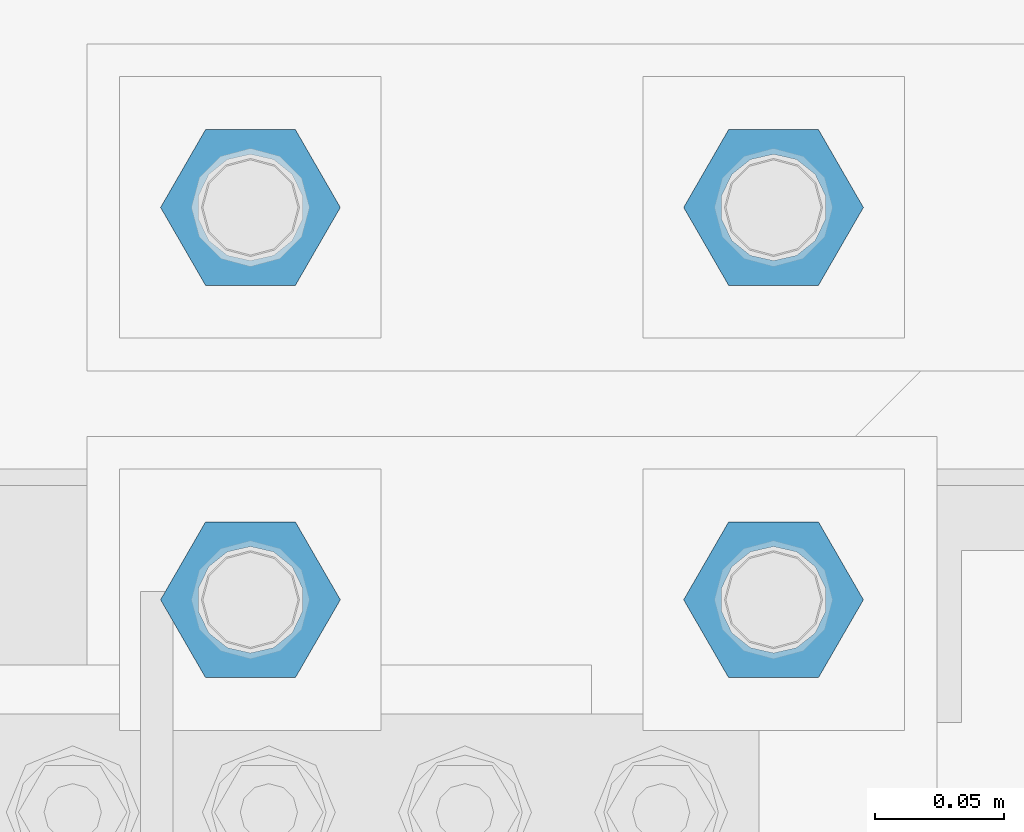
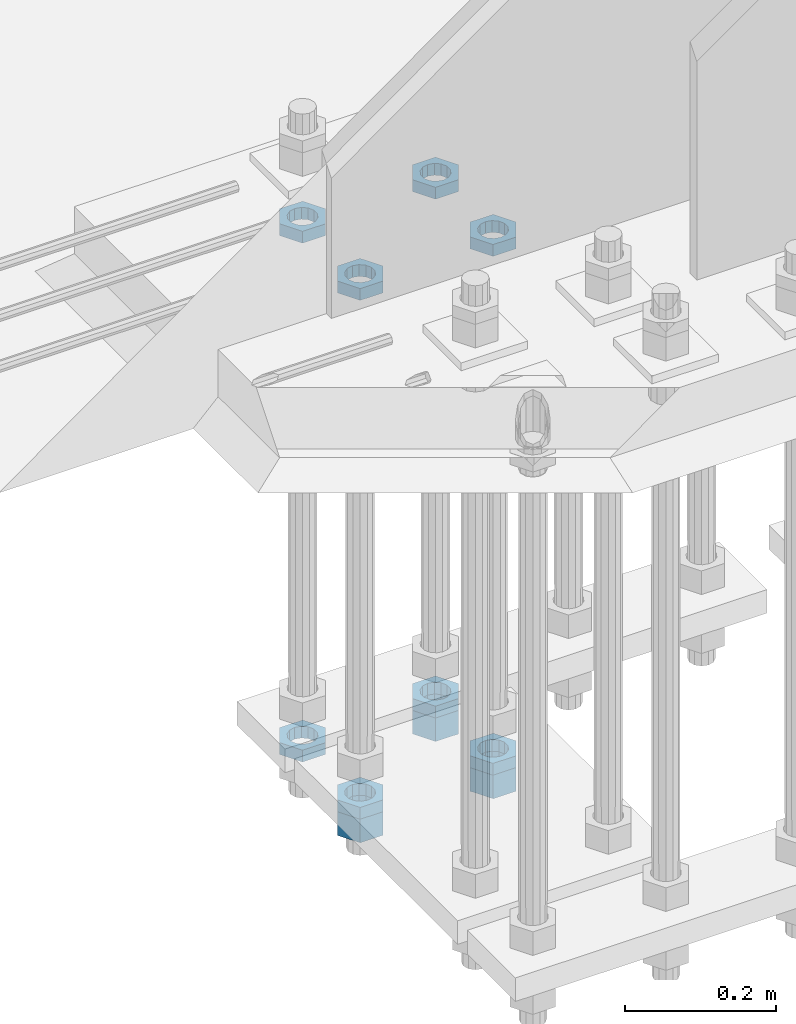
# One storey, part 2834 of 3843: 11 beams, 1 element without a shape of its own.
"""IFC2X3 building model written with IfcOpenShell, lengths in millimetres."""

from ifc_helpers import new_model, si_unit, frame, origin_with_axes, place, context, subcontext, project, spatial, faceted_brep, material, type_object, element, aggregate, save


model = new_model("IFC2X3")

# Units and contexts
model_context = context("Model", 3, precision=1e-05, world=origin_with_axes())
body_context = subcontext(model_context, "Body", "Model", "MODEL_VIEW")
ifc_project = project(units=[si_unit("LENGTHUNIT", "METRE", prefix="MILLI"), si_unit("AREAUNIT", "SQUARE_METRE"), si_unit("VOLUMEUNIT", "CUBIC_METRE"), si_unit("MASSUNIT", "GRAM", prefix="KILO"), si_unit("TIMEUNIT", "SECOND"), si_unit("PLANEANGLEUNIT", "RADIAN"), si_unit("SOLIDANGLEUNIT", "STERADIAN"), si_unit("THERMODYNAMICTEMPERATUREUNIT", "DEGREE_CELSIUS"), si_unit("LUMINOUSINTENSITYUNIT", "LUMEN")], contexts=[model_context])

# Site, building, storey
site_placement = place(None, origin_with_axes())
site = spatial("IfcSite", under=ifc_project, at=site_placement, CompositionType="ELEMENT")
building_placement = place(site_placement, origin_with_axes())
building = spatial("IfcBuilding", under=site, at=building_placement, Name="Undefined", CompositionType="ELEMENT")
storey_placement = place(building_placement, origin_with_axes())
storey = spatial("IfcBuildingStorey", under=building, at=storey_placement, Name="Undefined", CompositionType="ELEMENT", Elevation=0.0)

# Assembly, beams
assembly_placement = place(storey_placement, origin_with_axes())
assembly = element("IfcElementAssembly", 1, at=assembly_placement, inside=storey, Name="TEMPLATE", AssemblyPlace="NOTDEFINED", PredefinedType="RIGID_FRAME")
ifc_material = material(Name="STEEL/A572-50")
beam_type_1 = type_object("IfcBeamType", Name="1-1/2_HEAVY_HEX_NUT", PredefinedType="NOTDEFINED")
beam_1_placement = place(assembly_placement, frame((62331.6, 25768.3, 28746.4500015259), z_axis=(0.0, 1.0, 0.0), x_axis=(0.0, 0.0, -1.0)))
beam_1 = element("IfcBeam", 2, at=beam_1_placement, type_object=beam_type_1, material=ifc_material, Name="NUT", ObjectType="1-1/2_HEAVY_HEX_NUT", context=body_context, shape_type="Brep", body=[
    faceted_brep([(0.0, -34.9199981689453, 0.0), (0.0, -17.4599990844727, -30.25), (38.0999999999985, -17.4599990844727, -30.25), (38.0999999999985, -34.9199981689453, 0.0), (0.0, 17.4599990844727, -30.25), (38.0999999999985, 17.4599990844727, -30.25), (0.0, 34.9199981689453, 0.0), (38.0999999999985, 34.9199981689453, 0.0), (0.0, 17.4599990844727, 30.25), (38.0999999999985, 17.4599990844727, 30.25), (0.0, -17.4599990844727, 30.25), (38.0999999999985, -17.4599990844727, 30.25), (0.0, 0.0, 20.6399993896484), (0.0, 8.9553601105581, 18.5959968835959), (38.0999999999985, 8.9553601105581, 18.5959968835959), (38.0999999999985, 0.0, 20.6399993896484), (0.0, 16.1370013209525, 12.8688291298167), (38.0999999999985, 16.1370013209525, 12.8688291298167), (0.0, 20.1225115123816, 4.59283194104501), (38.0999999999985, 20.1225115123816, 4.59283194104501), (0.0, 20.1225115123816, -4.59283194104501), (38.0999999999985, 20.1225115123816, -4.59283194104501), (0.0, 16.1370013209525, -12.8688291298167), (38.0999999999985, 16.1370013209525, -12.8688291298167), (0.0, 8.9553601105581, -18.5959968835959), (38.0999999999985, 8.9553601105581, -18.5959968835959), (0.0, 0.0, -20.6399993896484), (38.0999999999985, 0.0, -20.6399993896484), (0.0, -8.9553601105581, -18.5959968835959), (38.0999999999985, -8.9553601105581, -18.5959968835959), (0.0, -16.1370013209525, -12.8688291298167), (38.0999999999985, -16.1370013209525, -12.8688291298167), (0.0, -20.1225115123816, -4.59283194104501), (38.0999999999985, -20.1225115123816, -4.59283194104501), (0.0, -20.1225115123816, 4.59283194104501), (38.0999999999985, -20.1225115123816, 4.59283194104501), (0.0, -16.1370013209525, 12.8688291298167), (38.0999999999985, -16.1370013209525, 12.8688291298167), (0.0, -8.9553601105581, 18.5959968835959), (38.0999999999985, -8.9553601105581, 18.5959968835959)], [[[0, 1, 2, 3]], [[1, 4, 5, 2]], [[4, 6, 7, 5]], [[6, 8, 9, 7]], [[8, 10, 11, 9]], [[10, 0, 3, 11]], [[12, 13, 14, 15]], [[13, 16, 17, 14]], [[16, 18, 19, 17]], [[18, 20, 21, 19]], [[20, 22, 23, 21]], [[22, 24, 25, 23]], [[24, 26, 27, 25]], [[26, 28, 29, 27]], [[28, 30, 31, 29]], [[30, 32, 33, 31]], [[32, 34, 35, 33]], [[34, 36, 37, 35]], [[36, 38, 39, 37]], [[38, 12, 15, 39]], [[5, 7, 9, 11, 3, 2], [17, 19, 21, 23, 25, 27, 29, 31, 33, 35, 37, 39, 15, 14]], [[10, 8, 6, 4, 1, 0], [38, 36, 34, 32, 30, 28, 26, 24, 22, 20, 18, 16, 13, 12]]]),
])
beam_2_placement = place(assembly_placement, frame((62128.4, 25768.3, 28746.4500015259), z_axis=(0.0, 1.0, 0.0), x_axis=(0.0, 0.0, -1.0)))
beam_2 = element("IfcBeam", 3, at=beam_2_placement, type_object=beam_type_1, material=ifc_material, Name="NUT", ObjectType="1-1/2_HEAVY_HEX_NUT", context=body_context, shape_type="Brep", body=[
    faceted_brep([(0.0, -34.9199981689453, 0.0), (0.0, -17.4599990844727, -30.25), (38.0999999999985, -17.4599990844727, -30.25), (38.0999999999985, -34.9199981689453, 0.0), (0.0, 17.4599990844727, -30.25), (38.0999999999985, 17.4599990844727, -30.25), (0.0, 34.9199981689453, 0.0), (38.0999999999985, 34.9199981689453, 0.0), (0.0, 17.4599990844727, 30.25), (38.0999999999985, 17.4599990844727, 30.25), (0.0, -17.4599990844727, 30.25), (38.0999999999985, -17.4599990844727, 30.25), (0.0, 0.0, 20.6399993896484), (0.0, 8.9553601105581, 18.5959968835959), (38.0999999999985, 8.9553601105581, 18.5959968835959), (38.0999999999985, 0.0, 20.6399993896484), (0.0, 16.1370013209525, 12.8688291298167), (38.0999999999985, 16.1370013209525, 12.8688291298167), (0.0, 20.1225115123816, 4.59283194104501), (38.0999999999985, 20.1225115123816, 4.59283194104501), (0.0, 20.1225115123816, -4.59283194104501), (38.0999999999985, 20.1225115123816, -4.59283194104501), (0.0, 16.1370013209525, -12.8688291298167), (38.0999999999985, 16.1370013209525, -12.8688291298167), (0.0, 8.9553601105581, -18.5959968835959), (38.0999999999985, 8.9553601105581, -18.5959968835959), (0.0, 0.0, -20.6399993896484), (38.0999999999985, 0.0, -20.6399993896484), (0.0, -8.9553601105581, -18.5959968835959), (38.0999999999985, -8.9553601105581, -18.5959968835959), (0.0, -16.1370013209525, -12.8688291298167), (38.0999999999985, -16.1370013209525, -12.8688291298167), (0.0, -20.1225115123816, -4.59283194104501), (38.0999999999985, -20.1225115123816, -4.59283194104501), (0.0, -20.1225115123816, 4.59283194104501), (38.0999999999985, -20.1225115123816, 4.59283194104501), (0.0, -16.1370013209525, 12.8688291298167), (38.0999999999985, -16.1370013209525, 12.8688291298167), (0.0, -8.9553601105581, 18.5959968835959), (38.0999999999985, -8.9553601105581, 18.5959968835959)], [[[0, 1, 2, 3]], [[1, 4, 5, 2]], [[4, 6, 7, 5]], [[6, 8, 9, 7]], [[8, 10, 11, 9]], [[10, 0, 3, 11]], [[12, 13, 14, 15]], [[13, 16, 17, 14]], [[16, 18, 19, 17]], [[18, 20, 21, 19]], [[20, 22, 23, 21]], [[22, 24, 25, 23]], [[24, 26, 27, 25]], [[26, 28, 29, 27]], [[28, 30, 31, 29]], [[30, 32, 33, 31]], [[32, 34, 35, 33]], [[34, 36, 37, 35]], [[36, 38, 39, 37]], [[38, 12, 15, 39]], [[5, 7, 9, 11, 3, 2], [17, 19, 21, 23, 25, 27, 29, 31, 33, 35, 37, 39, 15, 14]], [[10, 8, 6, 4, 1, 0], [38, 36, 34, 32, 30, 28, 26, 24, 22, 20, 18, 16, 13, 12]]]),
])
beam_3_placement = place(assembly_placement, frame((62331.6, 25920.7, 28746.4500015259), z_axis=(0.0, 1.0, 0.0), x_axis=(0.0, 0.0, -1.0)))
beam_3 = element("IfcBeam", 4, at=beam_3_placement, type_object=beam_type_1, material=ifc_material, Name="NUT", ObjectType="1-1/2_HEAVY_HEX_NUT", context=body_context, shape_type="Brep", body=[
    faceted_brep([(0.0, -34.9199981689453, 0.0), (0.0, -17.4599990844727, -30.25), (38.0999999999985, -17.4599990844727, -30.25), (38.0999999999985, -34.9199981689453, 0.0), (0.0, 17.4599990844727, -30.25), (38.0999999999985, 17.4599990844727, -30.25), (0.0, 34.9199981689453, 0.0), (38.0999999999985, 34.9199981689453, 0.0), (0.0, 17.4599990844727, 30.25), (38.0999999999985, 17.4599990844727, 30.25), (0.0, -17.4599990844727, 30.25), (38.0999999999985, -17.4599990844727, 30.25), (0.0, 0.0, 20.6399993896484), (0.0, 8.9553601105581, 18.5959968835959), (38.0999999999985, 8.9553601105581, 18.5959968835959), (38.0999999999985, 0.0, 20.6399993896484), (0.0, 16.1370013209525, 12.8688291298167), (38.0999999999985, 16.1370013209525, 12.8688291298167), (0.0, 20.1225115123816, 4.59283194104501), (38.0999999999985, 20.1225115123816, 4.59283194104501), (0.0, 20.1225115123816, -4.59283194104501), (38.0999999999985, 20.1225115123816, -4.59283194104501), (0.0, 16.1370013209525, -12.8688291298167), (38.0999999999985, 16.1370013209525, -12.8688291298167), (0.0, 8.9553601105581, -18.5959968835959), (38.0999999999985, 8.9553601105581, -18.5959968835959), (0.0, 0.0, -20.6399993896484), (38.0999999999985, 0.0, -20.6399993896484), (0.0, -8.9553601105581, -18.5959968835959), (38.0999999999985, -8.9553601105581, -18.5959968835959), (0.0, -16.1370013209525, -12.8688291298167), (38.0999999999985, -16.1370013209525, -12.8688291298167), (0.0, -20.1225115123816, -4.59283194104501), (38.0999999999985, -20.1225115123816, -4.59283194104501), (0.0, -20.1225115123816, 4.59283194104501), (38.0999999999985, -20.1225115123816, 4.59283194104501), (0.0, -16.1370013209525, 12.8688291298167), (38.0999999999985, -16.1370013209525, 12.8688291298167), (0.0, -8.9553601105581, 18.5959968835959), (38.0999999999985, -8.9553601105581, 18.5959968835959)], [[[0, 1, 2, 3]], [[1, 4, 5, 2]], [[4, 6, 7, 5]], [[6, 8, 9, 7]], [[8, 10, 11, 9]], [[10, 0, 3, 11]], [[12, 13, 14, 15]], [[13, 16, 17, 14]], [[16, 18, 19, 17]], [[18, 20, 21, 19]], [[20, 22, 23, 21]], [[22, 24, 25, 23]], [[24, 26, 27, 25]], [[26, 28, 29, 27]], [[28, 30, 31, 29]], [[30, 32, 33, 31]], [[32, 34, 35, 33]], [[34, 36, 37, 35]], [[36, 38, 39, 37]], [[38, 12, 15, 39]], [[5, 7, 9, 11, 3, 2], [17, 19, 21, 23, 25, 27, 29, 31, 33, 35, 37, 39, 15, 14]], [[10, 8, 6, 4, 1, 0], [38, 36, 34, 32, 30, 28, 26, 24, 22, 20, 18, 16, 13, 12]]]),
])
beam_type_2 = type_object("IfcBeamType", Name="1-1/2_HALF_NUT", PredefinedType="NOTDEFINED")
beam_4_placement = place(assembly_placement, frame((62331.6, 25920.7, 29603.7), z_axis=(0.0, -1.0, 0.0), x_axis=(0.0, 0.0, -1.0)))
beam_4 = element("IfcBeam", 5, at=beam_4_placement, type_object=beam_type_2, material=ifc_material, Name="NUT", ObjectType="1-1/2_HALF_NUT", context=body_context, shape_type="Brep", body=[
    faceted_brep([(0.0, -34.9199981689453, 0.0), (0.0, -17.4599990844727, -30.25), (19.0500000000029, -17.4599990844727, -30.25), (19.0500000000029, -34.9199981689453, 0.0), (0.0, 17.4599990844727, -30.25), (19.0500000000029, 17.4599990844727, -30.25), (0.0, 34.9199981689453, 0.0), (19.0500000000029, 34.9199981689453, 0.0), (0.0, 17.4599990844727, 30.25), (19.0500000000029, 17.4599990844727, 30.25), (0.0, -17.4599990844727, 30.25), (19.0500000000029, -17.4599990844727, 30.25), (0.0, 0.0, 20.6399993896484), (0.0, 8.9553601105581, 18.5959968835959), (19.0500000000029, 8.95536011056538, 18.5959968835959), (19.0500000000029, 0.0, 20.6399993896484), (0.0, 16.1370013209525, 12.8688291298167), (19.0500000000029, 16.1370013209489, 12.8688291298167), (0.0, 20.1225115123816, 4.59283194104501), (19.0500000000029, 20.1225115123852, 4.59283194104501), (0.0, 20.1225115123816, -4.59283194104501), (19.0500000000029, 20.1225115123852, -4.59283194104501), (0.0, 16.1370013209525, -12.8688291298167), (19.0500000000029, 16.1370013209489, -12.8688291298167), (0.0, 8.9553601105581, -18.5959968835959), (19.0500000000029, 8.95536011056538, -18.5959968835959), (0.0, 0.0, -20.6399993896484), (19.0500000000029, 0.0, -20.6399993896484), (0.0, -8.9553601105581, -18.5959968835959), (19.0500000000029, -8.95536011056538, -18.5959968835959), (0.0, -16.1370013209525, -12.8688291298167), (19.0500000000029, -16.1370013209489, -12.8688291298167), (0.0, -20.1225115123816, -4.59283194104501), (19.0500000000029, -20.1225115123852, -4.59283194104501), (0.0, -20.1225115123816, 4.59283194104501), (19.0500000000029, -20.1225115123852, 4.59283194104501), (0.0, -16.1370013209525, 12.8688291298167), (19.0500000000029, -16.1370013209489, 12.8688291298167), (0.0, -8.9553601105581, 18.5959968835959), (19.0500000000029, -8.95536011056538, 18.5959968835959)], [[[0, 1, 2, 3]], [[1, 4, 5, 2]], [[4, 6, 7, 5]], [[6, 8, 9, 7]], [[8, 10, 11, 9]], [[10, 0, 3, 11]], [[12, 13, 14, 15]], [[13, 16, 17, 14]], [[16, 18, 19, 17]], [[18, 20, 21, 19]], [[20, 22, 23, 21]], [[22, 24, 25, 23]], [[24, 26, 27, 25]], [[26, 28, 29, 27]], [[28, 30, 31, 29]], [[30, 32, 33, 31]], [[32, 34, 35, 33]], [[34, 36, 37, 35]], [[36, 38, 39, 37]], [[38, 12, 15, 39]], [[5, 7, 9, 11, 3, 2], [17, 19, 21, 23, 25, 27, 29, 31, 33, 35, 37, 39, 15, 14]], [[10, 8, 6, 4, 1, 0], [38, 36, 34, 32, 30, 28, 26, 24, 22, 20, 18, 16, 13, 12]]]),
])
beam_5_placement = place(assembly_placement, frame((62331.6, 25768.3, 29603.7), z_axis=(0.0, -1.0, 0.0), x_axis=(0.0, 0.0, -1.0)))
beam_5 = element("IfcBeam", 6, at=beam_5_placement, type_object=beam_type_2, material=ifc_material, Name="NUT", ObjectType="1-1/2_HALF_NUT", context=body_context, shape_type="Brep", body=[
    faceted_brep([(0.0, -34.9199981689453, 0.0), (0.0, -17.4599990844727, -30.25), (19.0500000000029, -17.4599990844727, -30.25), (19.0500000000029, -34.9199981689453, 0.0), (0.0, 17.4599990844727, -30.25), (19.0500000000029, 17.4599990844727, -30.25), (0.0, 34.9199981689453, 0.0), (19.0500000000029, 34.9199981689453, 0.0), (0.0, 17.4599990844727, 30.25), (19.0500000000029, 17.4599990844727, 30.25), (0.0, -17.4599990844727, 30.25), (19.0500000000029, -17.4599990844727, 30.25), (0.0, 0.0, 20.6399993896484), (0.0, 8.9553601105581, 18.5959968835959), (19.0500000000029, 8.95536011056538, 18.5959968835959), (19.0500000000029, 0.0, 20.6399993896484), (0.0, 16.1370013209525, 12.8688291298167), (19.0500000000029, 16.1370013209489, 12.8688291298167), (0.0, 20.1225115123816, 4.59283194104501), (19.0500000000029, 20.1225115123852, 4.59283194104501), (0.0, 20.1225115123816, -4.59283194104501), (19.0500000000029, 20.1225115123852, -4.59283194104501), (0.0, 16.1370013209525, -12.8688291298167), (19.0500000000029, 16.1370013209489, -12.8688291298167), (0.0, 8.9553601105581, -18.5959968835959), (19.0500000000029, 8.95536011056538, -18.5959968835959), (0.0, 0.0, -20.6399993896484), (19.0500000000029, 0.0, -20.6399993896484), (0.0, -8.9553601105581, -18.5959968835959), (19.0500000000029, -8.95536011056538, -18.5959968835959), (0.0, -16.1370013209525, -12.8688291298167), (19.0500000000029, -16.1370013209489, -12.8688291298167), (0.0, -20.1225115123816, -4.59283194104501), (19.0500000000029, -20.1225115123852, -4.59283194104501), (0.0, -20.1225115123816, 4.59283194104501), (19.0500000000029, -20.1225115123852, 4.59283194104501), (0.0, -16.1370013209525, 12.8688291298167), (19.0500000000029, -16.1370013209489, 12.8688291298167), (0.0, -8.9553601105581, 18.5959968835959), (19.0500000000029, -8.95536011056538, 18.5959968835959)], [[[0, 1, 2, 3]], [[1, 4, 5, 2]], [[4, 6, 7, 5]], [[6, 8, 9, 7]], [[8, 10, 11, 9]], [[10, 0, 3, 11]], [[12, 13, 14, 15]], [[13, 16, 17, 14]], [[16, 18, 19, 17]], [[18, 20, 21, 19]], [[20, 22, 23, 21]], [[22, 24, 25, 23]], [[24, 26, 27, 25]], [[26, 28, 29, 27]], [[28, 30, 31, 29]], [[30, 32, 33, 31]], [[32, 34, 35, 33]], [[34, 36, 37, 35]], [[36, 38, 39, 37]], [[38, 12, 15, 39]], [[5, 7, 9, 11, 3, 2], [17, 19, 21, 23, 25, 27, 29, 31, 33, 35, 37, 39, 15, 14]], [[10, 8, 6, 4, 1, 0], [38, 36, 34, 32, 30, 28, 26, 24, 22, 20, 18, 16, 13, 12]]]),
])
beam_6_placement = place(assembly_placement, frame((62128.4, 25920.7, 29603.7), z_axis=(0.0, -1.0, 0.0), x_axis=(0.0, 0.0, -1.0)))
beam_6 = element("IfcBeam", 7, at=beam_6_placement, type_object=beam_type_2, material=ifc_material, Name="NUT", ObjectType="1-1/2_HALF_NUT", context=body_context, shape_type="Brep", body=[
    faceted_brep([(0.0, -34.9199981689453, 0.0), (0.0, -17.4599990844727, -30.25), (19.0500000000029, -17.4599990844727, -30.25), (19.0500000000029, -34.9199981689453, 0.0), (0.0, 17.4599990844727, -30.25), (19.0500000000029, 17.4599990844727, -30.25), (0.0, 34.9199981689453, 0.0), (19.0500000000029, 34.9199981689453, 0.0), (0.0, 17.4599990844727, 30.25), (19.0500000000029, 17.4599990844727, 30.25), (0.0, -17.4599990844727, 30.25), (19.0500000000029, -17.4599990844727, 30.25), (0.0, 0.0, 20.6399993896484), (0.0, 8.9553601105581, 18.5959968835959), (19.0500000000029, 8.95536011056538, 18.5959968835959), (19.0500000000029, 0.0, 20.6399993896484), (0.0, 16.1370013209525, 12.8688291298167), (19.0500000000029, 16.1370013209489, 12.8688291298167), (0.0, 20.1225115123816, 4.59283194104501), (19.0500000000029, 20.1225115123852, 4.59283194104501), (0.0, 20.1225115123816, -4.59283194104501), (19.0500000000029, 20.1225115123852, -4.59283194104501), (0.0, 16.1370013209525, -12.8688291298167), (19.0500000000029, 16.1370013209489, -12.8688291298167), (0.0, 8.9553601105581, -18.5959968835959), (19.0500000000029, 8.95536011056538, -18.5959968835959), (0.0, 0.0, -20.6399993896484), (19.0500000000029, 0.0, -20.6399993896484), (0.0, -8.9553601105581, -18.5959968835959), (19.0500000000029, -8.95536011056538, -18.5959968835959), (0.0, -16.1370013209525, -12.8688291298167), (19.0500000000029, -16.1370013209489, -12.8688291298167), (0.0, -20.1225115123816, -4.59283194104501), (19.0500000000029, -20.1225115123852, -4.59283194104501), (0.0, -20.1225115123816, 4.59283194104501), (19.0500000000029, -20.1225115123852, 4.59283194104501), (0.0, -16.1370013209525, 12.8688291298167), (19.0500000000029, -16.1370013209489, 12.8688291298167), (0.0, -8.9553601105581, 18.5959968835959), (19.0500000000029, -8.95536011056538, 18.5959968835959)], [[[0, 1, 2, 3]], [[1, 4, 5, 2]], [[4, 6, 7, 5]], [[6, 8, 9, 7]], [[8, 10, 11, 9]], [[10, 0, 3, 11]], [[12, 13, 14, 15]], [[13, 16, 17, 14]], [[16, 18, 19, 17]], [[18, 20, 21, 19]], [[20, 22, 23, 21]], [[22, 24, 25, 23]], [[24, 26, 27, 25]], [[26, 28, 29, 27]], [[28, 30, 31, 29]], [[30, 32, 33, 31]], [[32, 34, 35, 33]], [[34, 36, 37, 35]], [[36, 38, 39, 37]], [[38, 12, 15, 39]], [[5, 7, 9, 11, 3, 2], [17, 19, 21, 23, 25, 27, 29, 31, 33, 35, 37, 39, 15, 14]], [[10, 8, 6, 4, 1, 0], [38, 36, 34, 32, 30, 28, 26, 24, 22, 20, 18, 16, 13, 12]]]),
])
beam_7_placement = place(assembly_placement, frame((62128.4, 25768.3, 29603.7), z_axis=(0.0, -1.0, 0.0), x_axis=(0.0, 0.0, -1.0)))
beam_7 = element("IfcBeam", 8, at=beam_7_placement, type_object=beam_type_2, material=ifc_material, Name="NUT", ObjectType="1-1/2_HALF_NUT", context=body_context, shape_type="Brep", body=[
    faceted_brep([(0.0, -34.9199981689453, 0.0), (0.0, -17.4599990844727, -30.25), (19.0500000000029, -17.4599990844727, -30.25), (19.0500000000029, -34.9199981689453, 0.0), (0.0, 17.4599990844727, -30.25), (19.0500000000029, 17.4599990844727, -30.25), (0.0, 34.9199981689453, 0.0), (19.0500000000029, 34.9199981689453, 0.0), (0.0, 17.4599990844727, 30.25), (19.0500000000029, 17.4599990844727, 30.25), (0.0, -17.4599990844727, 30.25), (19.0500000000029, -17.4599990844727, 30.25), (0.0, 0.0, 20.6399993896484), (0.0, 8.9553601105581, 18.5959968835959), (19.0500000000029, 8.95536011056538, 18.5959968835959), (19.0500000000029, 0.0, 20.6399993896484), (0.0, 16.1370013209525, 12.8688291298167), (19.0500000000029, 16.1370013209489, 12.8688291298167), (0.0, 20.1225115123816, 4.59283194104501), (19.0500000000029, 20.1225115123852, 4.59283194104501), (0.0, 20.1225115123816, -4.59283194104501), (19.0500000000029, 20.1225115123852, -4.59283194104501), (0.0, 16.1370013209525, -12.8688291298167), (19.0500000000029, 16.1370013209489, -12.8688291298167), (0.0, 8.9553601105581, -18.5959968835959), (19.0500000000029, 8.95536011056538, -18.5959968835959), (0.0, 0.0, -20.6399993896484), (19.0500000000029, 0.0, -20.6399993896484), (0.0, -8.9553601105581, -18.5959968835959), (19.0500000000029, -8.95536011056538, -18.5959968835959), (0.0, -16.1370013209525, -12.8688291298167), (19.0500000000029, -16.1370013209489, -12.8688291298167), (0.0, -20.1225115123816, -4.59283194104501), (19.0500000000029, -20.1225115123852, -4.59283194104501), (0.0, -20.1225115123816, 4.59283194104501), (19.0500000000029, -20.1225115123852, 4.59283194104501), (0.0, -16.1370013209525, 12.8688291298167), (19.0500000000029, -16.1370013209489, 12.8688291298167), (0.0, -8.9553601105581, 18.5959968835959), (19.0500000000029, -8.95536011056538, 18.5959968835959)], [[[0, 1, 2, 3]], [[1, 4, 5, 2]], [[4, 6, 7, 5]], [[6, 8, 9, 7]], [[8, 10, 11, 9]], [[10, 0, 3, 11]], [[12, 13, 14, 15]], [[13, 16, 17, 14]], [[16, 18, 19, 17]], [[18, 20, 21, 19]], [[20, 22, 23, 21]], [[22, 24, 25, 23]], [[24, 26, 27, 25]], [[26, 28, 29, 27]], [[28, 30, 31, 29]], [[30, 32, 33, 31]], [[32, 34, 35, 33]], [[34, 36, 37, 35]], [[36, 38, 39, 37]], [[38, 12, 15, 39]], [[5, 7, 9, 11, 3, 2], [17, 19, 21, 23, 25, 27, 29, 31, 33, 35, 37, 39, 15, 14]], [[10, 8, 6, 4, 1, 0], [38, 36, 34, 32, 30, 28, 26, 24, 22, 20, 18, 16, 13, 12]]]),
])
beam_8_placement = place(assembly_placement, frame((62331.6, 25768.3, 28765.5000015259), z_axis=(0.0, 1.0, 0.0), x_axis=(0.0, 0.0, -1.0)))
beam_8 = element("IfcBeam", 9, at=beam_8_placement, type_object=beam_type_2, material=ifc_material, Name="NUT", ObjectType="1-1/2_HALF_NUT", context=body_context, shape_type="Brep", body=[
    faceted_brep([(0.0, -34.9199981689453, 0.0), (0.0, -17.4599990844727, -30.25), (19.0500000000029, -17.4599990844727, -30.25), (19.0500000000029, -34.9199981689453, 0.0), (0.0, 17.4599990844727, -30.25), (19.0500000000029, 17.4599990844727, -30.25), (0.0, 34.9199981689453, 0.0), (19.0500000000029, 34.9199981689453, 0.0), (0.0, 17.4599990844727, 30.25), (19.0500000000029, 17.4599990844727, 30.25), (0.0, -17.4599990844727, 30.25), (19.0500000000029, -17.4599990844727, 30.25), (0.0, 0.0, 20.6399993896484), (0.0, 8.9553601105581, 18.5959968835959), (19.0500000000029, 8.95536011056538, 18.5959968835959), (19.0500000000029, 0.0, 20.6399993896484), (0.0, 16.1370013209525, 12.8688291298167), (19.0500000000029, 16.1370013209489, 12.8688291298167), (0.0, 20.1225115123816, 4.59283194104501), (19.0500000000029, 20.1225115123852, 4.59283194104501), (0.0, 20.1225115123816, -4.59283194104501), (19.0500000000029, 20.1225115123852, -4.59283194104501), (0.0, 16.1370013209525, -12.8688291298167), (19.0500000000029, 16.1370013209489, -12.8688291298167), (0.0, 8.9553601105581, -18.5959968835959), (19.0500000000029, 8.95536011056538, -18.5959968835959), (0.0, 0.0, -20.6399993896484), (19.0500000000029, 0.0, -20.6399993896484), (0.0, -8.9553601105581, -18.5959968835959), (19.0500000000029, -8.95536011056538, -18.5959968835959), (0.0, -16.1370013209525, -12.8688291298167), (19.0500000000029, -16.1370013209489, -12.8688291298167), (0.0, -20.1225115123816, -4.59283194104501), (19.0500000000029, -20.1225115123852, -4.59283194104501), (0.0, -20.1225115123816, 4.59283194104501), (19.0500000000029, -20.1225115123852, 4.59283194104501), (0.0, -16.1370013209525, 12.8688291298167), (19.0500000000029, -16.1370013209489, 12.8688291298167), (0.0, -8.9553601105581, 18.5959968835959), (19.0500000000029, -8.95536011056538, 18.5959968835959)], [[[0, 1, 2, 3]], [[1, 4, 5, 2]], [[4, 6, 7, 5]], [[6, 8, 9, 7]], [[8, 10, 11, 9]], [[10, 0, 3, 11]], [[12, 13, 14, 15]], [[13, 16, 17, 14]], [[16, 18, 19, 17]], [[18, 20, 21, 19]], [[20, 22, 23, 21]], [[22, 24, 25, 23]], [[24, 26, 27, 25]], [[26, 28, 29, 27]], [[28, 30, 31, 29]], [[30, 32, 33, 31]], [[32, 34, 35, 33]], [[34, 36, 37, 35]], [[36, 38, 39, 37]], [[38, 12, 15, 39]], [[5, 7, 9, 11, 3, 2], [17, 19, 21, 23, 25, 27, 29, 31, 33, 35, 37, 39, 15, 14]], [[10, 8, 6, 4, 1, 0], [38, 36, 34, 32, 30, 28, 26, 24, 22, 20, 18, 16, 13, 12]]]),
])
beam_9_placement = place(assembly_placement, frame((62128.4, 25768.3, 28765.5000015259), z_axis=(0.0, 1.0, 0.0), x_axis=(0.0, 0.0, -1.0)))
beam_9 = element("IfcBeam", 10, at=beam_9_placement, type_object=beam_type_2, material=ifc_material, Name="NUT", ObjectType="1-1/2_HALF_NUT", context=body_context, shape_type="Brep", body=[
    faceted_brep([(0.0, -34.9199981689453, 0.0), (0.0, -17.4599990844727, -30.25), (19.0500000000029, -17.4599990844727, -30.25), (19.0500000000029, -34.9199981689453, 0.0), (0.0, 17.4599990844727, -30.25), (19.0500000000029, 17.4599990844727, -30.25), (0.0, 34.9199981689453, 0.0), (19.0500000000029, 34.9199981689453, 0.0), (0.0, 17.4599990844727, 30.25), (19.0500000000029, 17.4599990844727, 30.25), (0.0, -17.4599990844727, 30.25), (19.0500000000029, -17.4599990844727, 30.25), (0.0, 0.0, 20.6399993896484), (0.0, 8.9553601105581, 18.5959968835959), (19.0500000000029, 8.95536011056538, 18.5959968835959), (19.0500000000029, 0.0, 20.6399993896484), (0.0, 16.1370013209525, 12.8688291298167), (19.0500000000029, 16.1370013209489, 12.8688291298167), (0.0, 20.1225115123816, 4.59283194104501), (19.0500000000029, 20.1225115123852, 4.59283194104501), (0.0, 20.1225115123816, -4.59283194104501), (19.0500000000029, 20.1225115123852, -4.59283194104501), (0.0, 16.1370013209525, -12.8688291298167), (19.0500000000029, 16.1370013209489, -12.8688291298167), (0.0, 8.9553601105581, -18.5959968835959), (19.0500000000029, 8.95536011056538, -18.5959968835959), (0.0, 0.0, -20.6399993896484), (19.0500000000029, 0.0, -20.6399993896484), (0.0, -8.9553601105581, -18.5959968835959), (19.0500000000029, -8.95536011056538, -18.5959968835959), (0.0, -16.1370013209525, -12.8688291298167), (19.0500000000029, -16.1370013209489, -12.8688291298167), (0.0, -20.1225115123816, -4.59283194104501), (19.0500000000029, -20.1225115123852, -4.59283194104501), (0.0, -20.1225115123816, 4.59283194104501), (19.0500000000029, -20.1225115123852, 4.59283194104501), (0.0, -16.1370013209525, 12.8688291298167), (19.0500000000029, -16.1370013209489, 12.8688291298167), (0.0, -8.9553601105581, 18.5959968835959), (19.0500000000029, -8.95536011056538, 18.5959968835959)], [[[0, 1, 2, 3]], [[1, 4, 5, 2]], [[4, 6, 7, 5]], [[6, 8, 9, 7]], [[8, 10, 11, 9]], [[10, 0, 3, 11]], [[12, 13, 14, 15]], [[13, 16, 17, 14]], [[16, 18, 19, 17]], [[18, 20, 21, 19]], [[20, 22, 23, 21]], [[22, 24, 25, 23]], [[24, 26, 27, 25]], [[26, 28, 29, 27]], [[28, 30, 31, 29]], [[30, 32, 33, 31]], [[32, 34, 35, 33]], [[34, 36, 37, 35]], [[36, 38, 39, 37]], [[38, 12, 15, 39]], [[5, 7, 9, 11, 3, 2], [17, 19, 21, 23, 25, 27, 29, 31, 33, 35, 37, 39, 15, 14]], [[10, 8, 6, 4, 1, 0], [38, 36, 34, 32, 30, 28, 26, 24, 22, 20, 18, 16, 13, 12]]]),
])
beam_10_placement = place(assembly_placement, frame((62331.6, 25920.7, 28765.5000015259), z_axis=(0.0, 1.0, 0.0), x_axis=(0.0, 0.0, -1.0)))
beam_10 = element("IfcBeam", 11, at=beam_10_placement, type_object=beam_type_2, material=ifc_material, Name="NUT", ObjectType="1-1/2_HALF_NUT", context=body_context, shape_type="Brep", body=[
    faceted_brep([(0.0, -34.9199981689453, 0.0), (0.0, -17.4599990844727, -30.25), (19.0500000000029, -17.4599990844727, -30.25), (19.0500000000029, -34.9199981689453, 0.0), (0.0, 17.4599990844727, -30.25), (19.0500000000029, 17.4599990844727, -30.25), (0.0, 34.9199981689453, 0.0), (19.0500000000029, 34.9199981689453, 0.0), (0.0, 17.4599990844727, 30.25), (19.0500000000029, 17.4599990844727, 30.25), (0.0, -17.4599990844727, 30.25), (19.0500000000029, -17.4599990844727, 30.25), (0.0, 0.0, 20.6399993896484), (0.0, 8.9553601105581, 18.5959968835959), (19.0500000000029, 8.95536011056538, 18.5959968835959), (19.0500000000029, 0.0, 20.6399993896484), (0.0, 16.1370013209525, 12.8688291298167), (19.0500000000029, 16.1370013209489, 12.8688291298167), (0.0, 20.1225115123816, 4.59283194104501), (19.0500000000029, 20.1225115123852, 4.59283194104501), (0.0, 20.1225115123816, -4.59283194104501), (19.0500000000029, 20.1225115123852, -4.59283194104501), (0.0, 16.1370013209525, -12.8688291298167), (19.0500000000029, 16.1370013209489, -12.8688291298167), (0.0, 8.9553601105581, -18.5959968835959), (19.0500000000029, 8.95536011056538, -18.5959968835959), (0.0, 0.0, -20.6399993896484), (19.0500000000029, 0.0, -20.6399993896484), (0.0, -8.9553601105581, -18.5959968835959), (19.0500000000029, -8.95536011056538, -18.5959968835959), (0.0, -16.1370013209525, -12.8688291298167), (19.0500000000029, -16.1370013209489, -12.8688291298167), (0.0, -20.1225115123816, -4.59283194104501), (19.0500000000029, -20.1225115123852, -4.59283194104501), (0.0, -20.1225115123816, 4.59283194104501), (19.0500000000029, -20.1225115123852, 4.59283194104501), (0.0, -16.1370013209525, 12.8688291298167), (19.0500000000029, -16.1370013209489, 12.8688291298167), (0.0, -8.9553601105581, 18.5959968835959), (19.0500000000029, -8.95536011056538, 18.5959968835959)], [[[0, 1, 2, 3]], [[1, 4, 5, 2]], [[4, 6, 7, 5]], [[6, 8, 9, 7]], [[8, 10, 11, 9]], [[10, 0, 3, 11]], [[12, 13, 14, 15]], [[13, 16, 17, 14]], [[16, 18, 19, 17]], [[18, 20, 21, 19]], [[20, 22, 23, 21]], [[22, 24, 25, 23]], [[24, 26, 27, 25]], [[26, 28, 29, 27]], [[28, 30, 31, 29]], [[30, 32, 33, 31]], [[32, 34, 35, 33]], [[34, 36, 37, 35]], [[36, 38, 39, 37]], [[38, 12, 15, 39]], [[5, 7, 9, 11, 3, 2], [17, 19, 21, 23, 25, 27, 29, 31, 33, 35, 37, 39, 15, 14]], [[10, 8, 6, 4, 1, 0], [38, 36, 34, 32, 30, 28, 26, 24, 22, 20, 18, 16, 13, 12]]]),
])
beam_11_placement = place(assembly_placement, frame((62128.399974823, 25920.7, 28765.5), z_axis=(0.0, 1.0, 0.0), x_axis=(0.0, 0.0, -1.0)))
beam_11 = element("IfcBeam", 12, at=beam_11_placement, type_object=beam_type_2, material=ifc_material, Name="NUT", ObjectType="1-1/2_HALF_NUT", context=body_context, shape_type="Brep", body=[
    faceted_brep([(0.0, -34.9199981689453, 0.0), (0.0, -17.4599990844727, -30.25), (19.0500000000029, -17.4599990844727, -30.25), (19.0500000000029, -34.9199981689453, 0.0), (0.0, 17.4599990844727, -30.25), (19.0500000000029, 17.4599990844727, -30.25), (0.0, 34.9199981689453, 0.0), (19.0500000000029, 34.9199981689453, 0.0), (0.0, 17.4599990844727, 30.25), (19.0500000000029, 17.4599990844727, 30.25), (0.0, -17.4599990844727, 30.25), (19.0500000000029, -17.4599990844727, 30.25), (0.0, 0.0, 20.6399993896484), (0.0, 8.9553601105581, 18.5959968835959), (19.0500000000029, 8.95536011056538, 18.5959968835959), (19.0500000000029, 0.0, 20.6399993896484), (0.0, 16.1370013209525, 12.8688291298167), (19.0500000000029, 16.1370013209489, 12.8688291298167), (0.0, 20.1225115123816, 4.59283194104501), (19.0500000000029, 20.1225115123852, 4.59283194104501), (0.0, 20.1225115123816, -4.59283194104501), (19.0500000000029, 20.1225115123852, -4.59283194104501), (0.0, 16.1370013209525, -12.8688291298167), (19.0500000000029, 16.1370013209489, -12.8688291298167), (0.0, 8.9553601105581, -18.5959968835959), (19.0500000000029, 8.95536011056538, -18.5959968835959), (0.0, 0.0, -20.6399993896484), (19.0500000000029, 0.0, -20.6399993896484), (0.0, -8.9553601105581, -18.5959968835959), (19.0500000000029, -8.95536011056538, -18.5959968835959), (0.0, -16.1370013209525, -12.8688291298167), (19.0500000000029, -16.1370013209489, -12.8688291298167), (0.0, -20.1225115123816, -4.59283194104501), (19.0500000000029, -20.1225115123852, -4.59283194104501), (0.0, -20.1225115123816, 4.59283194104501), (19.0500000000029, -20.1225115123852, 4.59283194104501), (0.0, -16.1370013209525, 12.8688291298167), (19.0500000000029, -16.1370013209489, 12.8688291298167), (0.0, -8.9553601105581, 18.5959968835959), (19.0500000000029, -8.95536011056538, 18.5959968835959)], [[[0, 1, 2, 3]], [[1, 4, 5, 2]], [[4, 6, 7, 5]], [[6, 8, 9, 7]], [[8, 10, 11, 9]], [[10, 0, 3, 11]], [[12, 13, 14, 15]], [[13, 16, 17, 14]], [[16, 18, 19, 17]], [[18, 20, 21, 19]], [[20, 22, 23, 21]], [[22, 24, 25, 23]], [[24, 26, 27, 25]], [[26, 28, 29, 27]], [[28, 30, 31, 29]], [[30, 32, 33, 31]], [[32, 34, 35, 33]], [[34, 36, 37, 35]], [[36, 38, 39, 37]], [[38, 12, 15, 39]], [[5, 7, 9, 11, 3, 2], [17, 19, 21, 23, 25, 27, 29, 31, 33, 35, 37, 39, 15, 14]], [[10, 8, 6, 4, 1, 0], [38, 36, 34, 32, 30, 28, 26, 24, 22, 20, 18, 16, 13, 12]]]),
])
aggregate(assembly, [beam_4, beam_5, beam_6, beam_7, beam_8, beam_9, beam_10, beam_11, beam_1, beam_2, beam_3])

save(model, "model.ifc")
